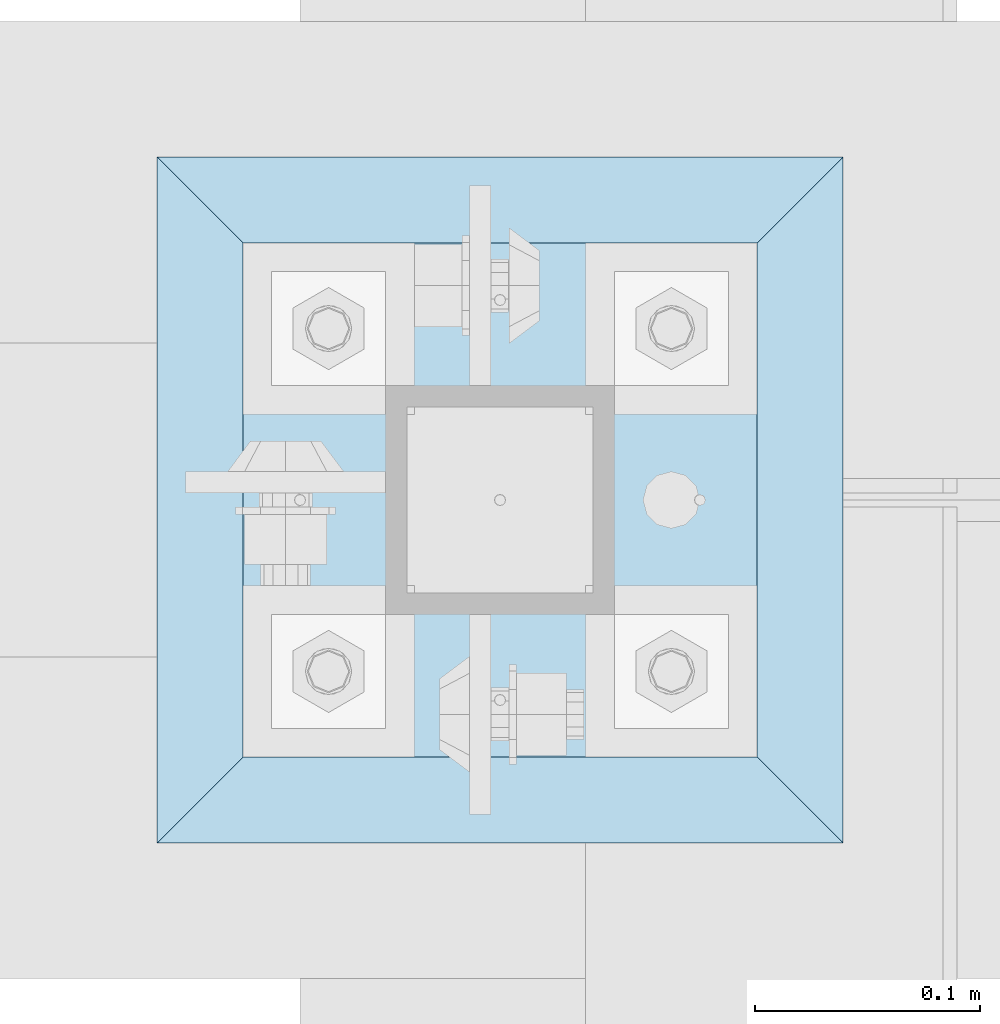
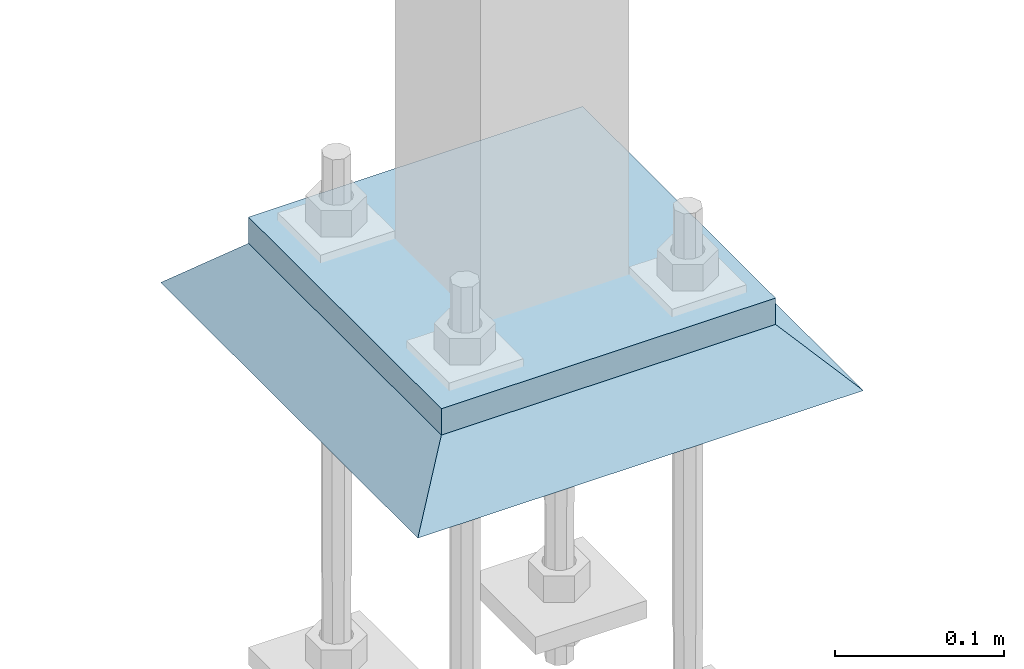
# One storey, part 3283 of 3843: 2 plates, 2 elements without a shape of their own.
"""IFC2X3 building model written with IfcOpenShell, lengths in millimetres."""

from ifc_helpers import new_model, si_unit, frame, origin_with_axes, place, context, subcontext, project, spatial, faceted_brep, material, type_object, element, aggregate, save


model = new_model("IFC2X3")

# Units and contexts
model_context = context("Model", 3, precision=1e-05, world=origin_with_axes())
body_context = subcontext(model_context, "Body", "Model", "MODEL_VIEW")
ifc_project = project(units=[si_unit("LENGTHUNIT", "METRE", prefix="MILLI"), si_unit("AREAUNIT", "SQUARE_METRE"), si_unit("VOLUMEUNIT", "CUBIC_METRE"), si_unit("MASSUNIT", "GRAM", prefix="KILO"), si_unit("TIMEUNIT", "SECOND"), si_unit("PLANEANGLEUNIT", "RADIAN"), si_unit("SOLIDANGLEUNIT", "STERADIAN"), si_unit("THERMODYNAMICTEMPERATUREUNIT", "DEGREE_CELSIUS"), si_unit("LUMINOUSINTENSITYUNIT", "LUMEN")], contexts=[model_context])

# Site, building, storey
site_placement = place(None, origin_with_axes())
site = spatial("IfcSite", under=ifc_project, at=site_placement, CompositionType="ELEMENT")
building_placement = place(site_placement, origin_with_axes())
building = spatial("IfcBuilding", under=site, at=building_placement, Name="Undefined", CompositionType="ELEMENT")
storey_placement = place(building_placement, origin_with_axes())
storey = spatial("IfcBuildingStorey", under=building, at=storey_placement, Name="Undefined", CompositionType="ELEMENT", Elevation=0.0)

# Assembly, plate
assembly_1_placement = place(storey_placement, origin_with_axes())
assembly_1 = element("IfcElementAssembly", 1, at=assembly_1_placement, inside=storey, Name="COLUMN", AssemblyPlace="NOTDEFINED", PredefinedType="RIGID_FRAME")
ifc_material_1 = material(Name="STEEL/A572-50")
plate_type_1 = type_object("IfcPlateType", PredefinedType="NOTDEFINED")
plate_1_placement = place(assembly_1_placement, frame((38706.425, 58801.0, 30070.425), z_axis=(0.0, 1.0, 0.0), x_axis=(1.0, 0.0, 0.0)))
plate_1 = element("IfcPlate", 2, at=plate_1_placement, type_object=plate_type_1, material=ifc_material_1, Name="PLATE", context=body_context, shape_type="Brep", body=[
    faceted_brep([(0.0, -9.52500000000146, 0.0), (0.0, -9.52500000000146, 228.600006103516), (0.0, 9.52500000000146, 228.600006103516), (0.0, 9.52500000000146, 0.0), (228.600006103516, -9.52500000000146, 228.600006103516), (228.600006103516, 9.52500000000146, 228.600006103516), (228.599999999999, -9.52500000000146, 0.0), (228.599999999999, 9.52500000000146, 0.0)], [[[0, 1, 2, 3]], [[1, 4, 5, 2]], [[4, 6, 7, 5]], [[6, 0, 3, 7]], [[5, 7, 3, 2]], [[6, 4, 1, 0]]]),
])
aggregate(assembly_1, [plate_1])

assembly_2_placement = place(storey_placement, origin_with_axes())
assembly_2 = element("IfcElementAssembly", 3, at=assembly_2_placement, inside=storey, Name="GROUT", AssemblyPlace="NOTDEFINED", PredefinedType="REINFORCEMENT_UNIT")
ifc_material_2 = material(Name="CONCRETE/Concrete_Undefined")
plate_type_2 = type_object("IfcPlateType", PredefinedType="NOTDEFINED")
plate_2_placement = place(assembly_2_placement, frame((38668.325, 58762.9, 30041.85), z_axis=(0.0, 1.0, 0.0), x_axis=(1.0, 0.0, 0.0)))
plate_2 = element("IfcPlate", 4, at=plate_2_placement, type_object=plate_type_2, material=ifc_material_2, Name="GROUT", context=body_context, shape_type="Brep", body=[
    faceted_brep([(38.0999999997875, -19.0499999997883, 266.699999999328), (0.0, 19.0499999999993, 304.799987792969), (0.0, 19.0500000000029, 0.0), (38.1000000006916, -19.0499999999811, 38.1000000006607), (266.700000000201, -19.0499999998174, 38.1000000006752), (304.799987792969, 19.0499999999993, 0.0), (304.799987792969, 19.0499999999993, 304.799987792969), (266.700000000201, -19.0499999999738, 266.699999999328)], [[[0, 1, 2, 3]], [[4, 5, 6, 7]], [[4, 7, 0, 3]], [[5, 4, 3, 2]], [[6, 5, 2, 1]], [[7, 6, 1, 0]]]),
])
aggregate(assembly_2, [plate_2])

save(model, "model.ifc")
